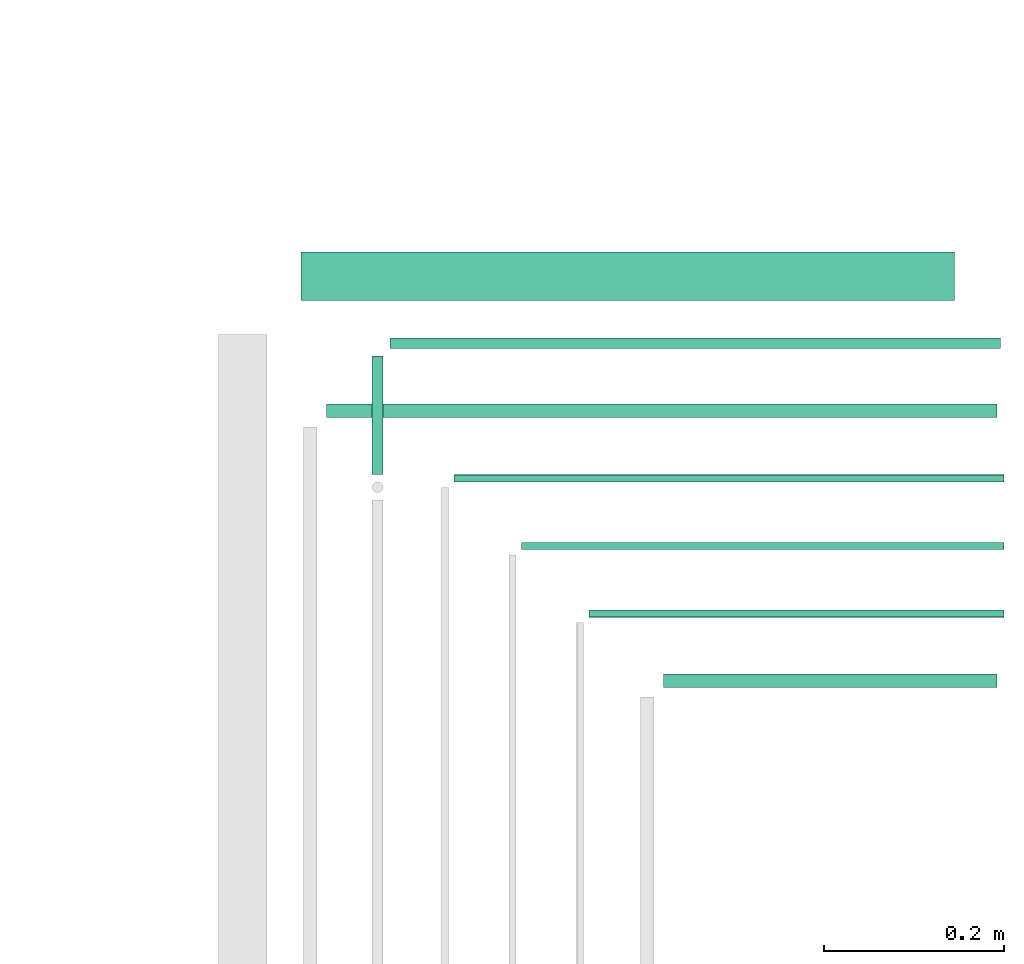
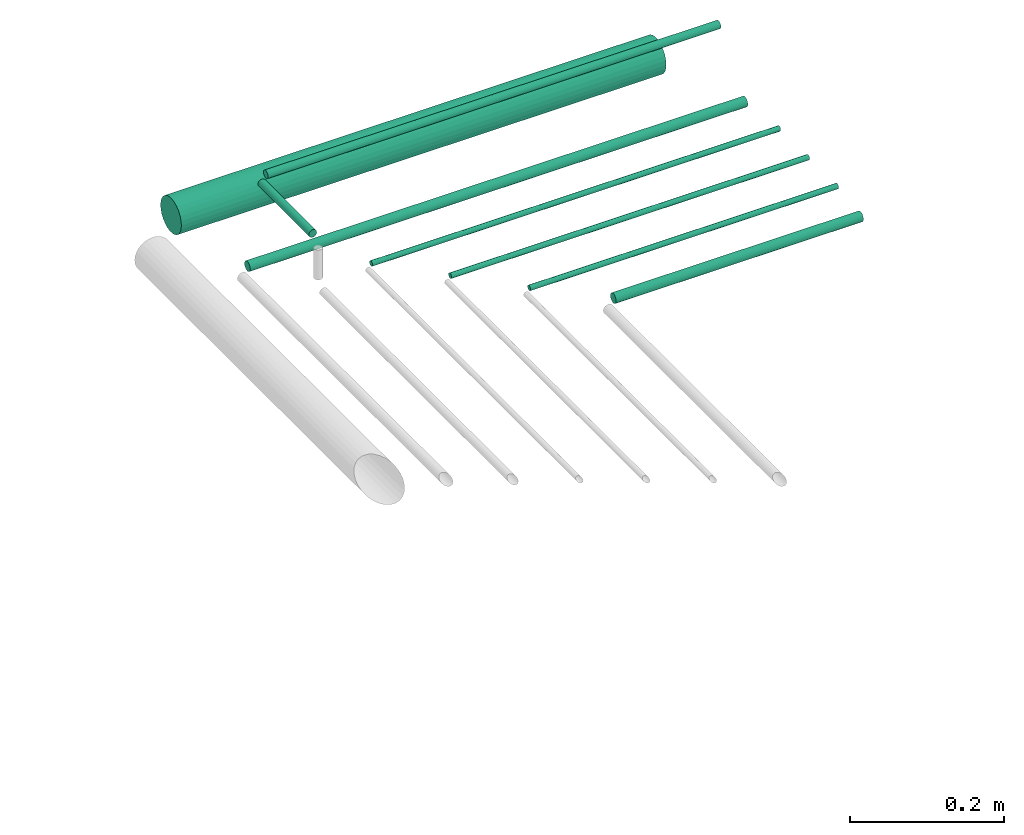
# One storey, part 47 of 65: 8 flow segments.
"""IFC2X3 building model written with IfcOpenShell, lengths in millimetres."""

import ifcopenshell
import ifcopenshell.guid

model = None  # the IFC model being written
_history = None  # IfcOwnerHistory: only IFC2X3 demands one
_inside = {}  # id of a spatial element -> (the spatial element, [elements in it])
_under = {}  # id of a project, library or spatial element -> (it, [spatial elements below it])
_declared = {}  # id of a project -> (the project, [libraries it declares])
_typed = {}  # id of a type object -> (the type object, [elements of that type])
_made_of = {}  # id of a material, layer set ... -> (it, [elements and type objects made of it])


def new_model(schema):
    """Start an empty IFC model of exactly this schema.

    Asked for "IFC4X3", IfcOpenShell would pick the latest addendum, in which some entities
    have other attributes; the version numbers below select the first issue.
    IFC2X3 requires an IfcOwnerHistory on every rooted entity: one is made here for all.
    """
    global model, _history
    if schema == "IFC4X3":
        model = ifcopenshell.file(schema_version=(4, 3, 0, 0))
    else:
        model = ifcopenshell.file(schema=schema)
    _inside.clear()
    _under.clear()
    _declared.clear()
    _typed.clear()
    _made_of.clear()
    _history = None
    if model.schema == "IFC2X3":
        org = make("IfcOrganization", Name="unknown")
        user = make(
            "IfcPersonAndOrganization",
            ThePerson=make("IfcPerson", FamilyName="unknown"),
            TheOrganization=org,
        )
        app = make(
            "IfcApplication",
            ApplicationDeveloper=org,
            Version="unknown",
            ApplicationFullName="unknown",
            ApplicationIdentifier="unknown",
        )
        _history = make(
            "IfcOwnerHistory",
            OwningUser=user,
            OwningApplication=app,
            ChangeAction="ADDED",
            CreationDate=0,
        )
    return model


def make(cls, **values):
    """One entity of the class cls with the attributes given. An attribute that is None is left unset."""
    return model.create_entity(
        cls, **{name: value for name, value in values.items() if value is not None}
    )


def entity(cls, *values):
    """Any entity or typed value of the class cls, its attributes in the order of the schema. None: left unset."""
    e = model.create_entity(cls)
    for i, value in enumerate(values):
        if value is not None:
            e[i] = value
    return e


def rooted(cls, **values):
    """An entity with a GlobalId (a new one), such as an element, a storey or a relation."""
    return make(cls, GlobalId=ifcopenshell.guid.new(), OwnerHistory=_history, **values)


def si_unit(unit_type, name, prefix=None):
    """IfcSIUnit, for example si_unit("LENGTHUNIT", "METRE", prefix="MILLI")."""
    return make("IfcSIUnit", UnitType=unit_type, Prefix=prefix, Name=name)


def converted_unit(unit_type, name, factor, base, dimensions=None, offset=None):
    """IfcConversionBasedUnit, such as the inch: factor (a typed value) times the base unit."""
    return make(
        "IfcConversionBasedUnit"
        if offset is None
        else "IfcConversionBasedUnitWithOffset",
        ConversionOffset=offset,
        Dimensions=None
        if dimensions is None
        else entity("IfcDimensionalExponents", *dimensions),
        UnitType=unit_type,
        Name=name,
        ConversionFactor=make(
            "IfcMeasureWithUnit", ValueComponent=factor, UnitComponent=base
        ),
    )


def derived_unit(unit_type, elements):
    """IfcDerivedUnit: a product of units, each with its exponent."""
    return make(
        "IfcDerivedUnit",
        Elements=[
            make("IfcDerivedUnitElement", Unit=unit, Exponent=power)
            for unit, power in elements
        ],
        UnitType=unit_type,
    )


def assignment(units):
    """IfcUnitAssignment: the units of a project."""
    return None if units is None else make("IfcUnitAssignment", Units=units)


def point(xyz):
    """IfcCartesianPoint."""
    return None if xyz is None else make("IfcCartesianPoint", Coordinates=xyz)


def direction(xyz):
    """IfcDirection."""
    return None if xyz is None else make("IfcDirection", DirectionRatios=xyz)


def frame(location, z_axis=None, x_axis=None):
    """IfcAxis2Placement3D, a coordinate frame: its origin and axes. An axis left out is left unset."""
    return make(
        "IfcAxis2Placement3D",
        Location=point(location),
        Axis=direction(z_axis),
        RefDirection=direction(x_axis),
    )


def frame_2d(location, x_axis=None):
    """IfcAxis2Placement2D, a coordinate frame in the plane: its origin and x axis."""
    return make(
        "IfcAxis2Placement2D", Location=point(location), RefDirection=direction(x_axis)
    )


def origin():
    """The frame at (0, 0, 0) with its axes left unset."""
    return frame((0.0, 0.0, 0.0))


def origin_2d_with_axis():
    """The frame at (0, 0) in the plane with the x axis (1, 0) written out."""
    return frame_2d((0.0, 0.0), x_axis=(1.0, 0.0))


def place(relative_to, where):
    """IfcLocalPlacement: puts the frame where relative to a parent placement (None: the world)."""
    return make(
        "IfcLocalPlacement", PlacementRelTo=relative_to, RelativePlacement=where
    )


def context(
    kind, dimensions, precision=None, world=None, true_north=None, identifier=None
):
    """IfcGeometricRepresentationContext, for example the 3D "Model" context."""
    return make(
        "IfcGeometricRepresentationContext",
        ContextIdentifier=identifier,
        ContextType=kind,
        CoordinateSpaceDimension=dimensions,
        Precision=precision,
        WorldCoordinateSystem=world,
        TrueNorth=true_north,
    )


def subcontext(parent, identifier, kind, view, scale=None):
    """IfcGeometricRepresentationSubContext, for example "Body" below "Model"."""
    return make(
        "IfcGeometricRepresentationSubContext",
        ContextIdentifier=identifier,
        ContextType=kind,
        ParentContext=parent,
        TargetScale=scale,
        TargetView=view,
    )


def project(units=None, contexts=None):
    """IfcProject with its units and contexts."""
    return rooted(
        "IfcProject",
        Name="project",
        RepresentationContexts=contexts,
        UnitsInContext=assignment(units),
    )


def spatial(cls, under=None, at=None, **own):
    """A site, building, storey or space (cls), placed at a placement, below another one or the project."""
    s = rooted(cls, ObjectPlacement=at, **own)
    if under is not None:
        _under.setdefault(under.id(), (under, []))[1].append(s)
    return s


def profile(cls, at=None, kind="AREA", **sizes):
    """A parametric profile (cls). Its sizes go by their IFC names, for example OverallWidth=200.0."""
    return make(cls, ProfileType=kind, Position=at, **sizes)


def circle(**sizes):
    """IfcCircleProfileDef."""
    return profile("IfcCircleProfileDef", **sizes)


def extrude(swept, where, along, depth):
    """IfcExtrudedAreaSolid: the profile swept, set in the frame where, extruded along a direction by depth."""
    return make(
        "IfcExtrudedAreaSolid",
        SweptArea=swept,
        Position=where,
        ExtrudedDirection=direction(along),
        Depth=depth,
    )


def shape(context_of_items, identifier, shape_type, items):
    """IfcShapeRepresentation: the items that make up one representation, for example the "Body"."""
    return make(
        "IfcShapeRepresentation",
        ContextOfItems=context_of_items,
        RepresentationIdentifier=identifier,
        RepresentationType=shape_type,
        Items=items,
    )


def made_of(thing, what):
    """Note that an element or type object is made of a material, layer set ...; save() writes the relation."""
    if what is not None:
        _made_of.setdefault(what.id(), (what, []))[1].append(thing)
    return thing


def type_object(cls, material=None, **own):
    """A type object (cls), such as IfcWallType, which elements share."""
    return made_of(rooted(cls, **own), material)


def element(
    cls,
    number,
    at=None,
    inside=None,
    cuts=None,
    type_object=None,
    material=None,
    context=None,
    identifier="Body",
    shape_type=None,
    held_by="IfcProductDefinitionShape",
    body=None,
    shapes=None,
    **own,
):
    """One element of the class cls, such as IfcWall. Its Tag is "e" and its number.

    at: its placement. inside: the storey or other place that contains it. cuts: it is an
    opening in that element (IfcRelVoidsElement). A single representation is given by context,
    identifier, shape_type and body (its items); several are given by shapes. held_by: the class
    of the entity that holds the representations. save() writes the other relations.
    """
    e = rooted(cls, Tag="e%d" % number, ObjectPlacement=at, **own)
    if body is not None:
        shapes = [shape(context, identifier, shape_type, body)]
    if shapes is not None:
        e.Representation = make(held_by, Representations=shapes)
    if inside is not None:
        _inside.setdefault(inside.id(), (inside, []))[1].append(e)
    if cuts is not None:
        rooted(
            "IfcRelVoidsElement", RelatingBuildingElement=cuts, RelatedOpeningElement=e
        )
    if type_object is not None:
        _typed.setdefault(type_object.id(), (type_object, []))[1].append(e)
    return made_of(e, material)


def aggregate(whole, parts):
    """IfcRelAggregates: a whole, such as a stair, and the parts it consists of."""
    return rooted("IfcRelAggregates", RelatingObject=whole, RelatedObjects=parts)


def save(model, path):
    """Write the relations noted so far, then the file.

    IfcRelAggregates (storeys below a building ...), IfcRelContainedInSpatialStructure (elements
    in a storey), IfcRelDefinesByType, IfcRelAssociatesMaterial and IfcRelDeclares: one each for
    every whole, place, type object, material and project.
    """
    for whole, parts in _under.values():
        aggregate(whole, parts)
    for where, things in _inside.values():
        rooted(
            "IfcRelContainedInSpatialStructure",
            RelatedElements=things,
            RelatingStructure=where,
        )
    for kind, things in _typed.values():
        rooted("IfcRelDefinesByType", RelatedObjects=things, RelatingType=kind)
    for what, things in _made_of.values():
        rooted("IfcRelAssociatesMaterial", RelatedObjects=things, RelatingMaterial=what)
    for by, libraries in _declared.values():
        rooted("IfcRelDeclares", RelatingContext=by, RelatedDefinitions=libraries)
    model.write(path)


model = new_model("IFC2X3")

# Units and contexts
model_context = context("Model", 3, precision=0.01, world=origin(), true_north=direction((6.12303176911189e-17, 1.0)))
body_context = subcontext(model_context, "Body", "Model", "MODEL_VIEW")
ifc_project = project(units=[si_unit("LENGTHUNIT", "METRE", prefix="MILLI"), si_unit("AREAUNIT", "SQUARE_METRE"), si_unit("VOLUMEUNIT", "CUBIC_METRE"), converted_unit("PLANEANGLEUNIT", "DEGREE", entity("IfcRatioMeasure", 0.0174532925199433), si_unit("PLANEANGLEUNIT", "RADIAN"), dimensions=[0, 0, 0, 0, 0, 0, 0]), si_unit("MASSUNIT", "GRAM", prefix="KILO"), derived_unit("MASSDENSITYUNIT", [(si_unit("MASSUNIT", "GRAM", prefix="KILO"), 1), (si_unit("LENGTHUNIT", "METRE"), -3)]), derived_unit("MOMENTOFINERTIAUNIT", [(si_unit("LENGTHUNIT", "METRE"), 4)]), si_unit("TIMEUNIT", "SECOND"), si_unit("FREQUENCYUNIT", "HERTZ"), si_unit("THERMODYNAMICTEMPERATUREUNIT", "DEGREE_CELSIUS"), derived_unit("THERMALTRANSMITTANCEUNIT", [(si_unit("MASSUNIT", "GRAM", prefix="KILO"), 1), (si_unit("THERMODYNAMICTEMPERATUREUNIT", "KELVIN"), -1), (si_unit("TIMEUNIT", "SECOND"), -3)]), derived_unit("VOLUMETRICFLOWRATEUNIT", [(si_unit("LENGTHUNIT", "METRE"), 3), (si_unit("TIMEUNIT", "SECOND"), -1)]), derived_unit("MASSFLOWRATEUNIT", [(si_unit("MASSUNIT", "GRAM", prefix="KILO"), 1), (si_unit("TIMEUNIT", "SECOND"), -1)]), derived_unit("ROTATIONALFREQUENCYUNIT", [(si_unit("TIMEUNIT", "SECOND"), -1)]), si_unit("ELECTRICCURRENTUNIT", "AMPERE"), si_unit("ELECTRICVOLTAGEUNIT", "VOLT"), si_unit("POWERUNIT", "WATT"), si_unit("FORCEUNIT", "NEWTON", prefix="KILO"), si_unit("ILLUMINANCEUNIT", "LUX"), si_unit("LUMINOUSFLUXUNIT", "LUMEN"), si_unit("LUMINOUSINTENSITYUNIT", "CANDELA"), derived_unit("USERDEFINED", [(si_unit("MASSUNIT", "GRAM", prefix="KILO"), -1), (si_unit("LENGTHUNIT", "METRE"), -2), (si_unit("TIMEUNIT", "SECOND"), 3), (si_unit("LUMINOUSFLUXUNIT", "LUMEN"), 1)]), derived_unit("LINEARVELOCITYUNIT", [(si_unit("LENGTHUNIT", "METRE"), 1), (si_unit("TIMEUNIT", "SECOND"), -1)]), si_unit("PRESSUREUNIT", "PASCAL"), derived_unit("USERDEFINED", [(si_unit("LENGTHUNIT", "METRE"), -2), (si_unit("MASSUNIT", "GRAM", prefix="KILO"), 1), (si_unit("TIMEUNIT", "SECOND"), -2)]), derived_unit("LINEARFORCEUNIT", [(si_unit("MASSUNIT", "GRAM", prefix="KILO"), 1), (si_unit("LENGTHUNIT", "METRE"), 1), (si_unit("TIMEUNIT", "SECOND"), -2), (si_unit("LENGTHUNIT", "METRE"), -1)]), derived_unit("PLANARFORCEUNIT", [(si_unit("MASSUNIT", "GRAM", prefix="KILO"), 1), (si_unit("LENGTHUNIT", "METRE"), 1), (si_unit("TIMEUNIT", "SECOND"), -2), (si_unit("LENGTHUNIT", "METRE"), -2)])], contexts=[model_context])

# Site, building, storey
site_placement = place(None, frame((0.0, -0.00077364408347762, 0.0)))
site = spatial("IfcSite", under=ifc_project, at=site_placement, CompositionType="ELEMENT")
building_placement = place(site_placement, origin())
building = spatial("IfcBuilding", under=site, at=building_placement, CompositionType="ELEMENT")
storey_placement = place(building_placement, frame((0.0, 0.0, 19800.0)))
storey = spatial("IfcBuildingStorey", under=building, at=storey_placement, CompositionType="ELEMENT", Elevation=19800.0)

# Flow segments
pipe_segment_type = type_object("IfcPipeSegmentType", PredefinedType="NOTDEFINED")
flow_segment_1_placement = place(storey_placement, frame((72918.1766297108, 10350.7754696782, 3040.90472776408)))
element("IfcFlowSegment", 1, at=flow_segment_1_placement, inside=storey, type_object=pipe_segment_type, context=body_context, shape_type="SweptSolid", body=[
    extrude(circle(Radius=7.5, at=frame_2d((-2.16573425859679e-12, 0.0), x_axis=(1.0, 0.0))), frame((0.0, 9.09527223591636, 9.09527223591419), z_axis=(1.0, 0.0, 0.0), x_axis=(0.0, 1.0, 0.0)), (0.0, 0.0, 1.0), 370.520903233842),
])
flow_segment_2_placement = place(storey_placement, frame((72835.1766297108, 10428.8573992404, 3044.40472776407)))
element("IfcFlowSegment", 2, at=flow_segment_2_placement, inside=storey, type_object=pipe_segment_type, context=body_context, shape_type="SweptSolid", body=[
    extrude(circle(Radius=4.0, at=frame_2d((-4.33146851719357e-12, 0.0), x_axis=(1.0, 0.0))), frame((0.0, 5.59527223591932, 5.59527223591499), z_axis=(1.0, 0.0, 0.0), x_axis=(0.0, 1.0, 0.0)), (0.0, 0.0, 1.0), 461.520903233838),
])
flow_segment_3_placement = place(storey_placement, frame((72760.1766297108, 10504.10062571, 3044.40472776407)))
element("IfcFlowSegment", 3, at=flow_segment_3_placement, inside=storey, type_object=pipe_segment_type, context=body_context, shape_type="SweptSolid", body=[
    extrude(circle(Radius=4.0, at=frame_2d((-6.49720277579036e-12, 0.0), x_axis=(1.0, 0.0))), frame((0.0, 5.59527223592149, 5.59527223591499), z_axis=(1.0, 0.0, 0.0), x_axis=(0.0, 1.0, 0.0)), (0.0, 0.0, 1.0), 536.520903233847),
])
flow_segment_4_placement = place(storey_placement, frame((72685.1766297108, 10579.3450681631, 3044.40472776407)))
element("IfcFlowSegment", 4, at=flow_segment_4_placement, inside=storey, type_object=pipe_segment_type, context=body_context, shape_type="SweptSolid", body=[
    extrude(circle(Radius=4.0, at=frame_2d((-6.49720277579036e-12, 0.0), x_axis=(1.0, 0.0))), frame((0.0, 5.59527223592149, 5.59527223591499), z_axis=(1.0, 0.0, 0.0), x_axis=(0.0, 1.0, 0.0)), (0.0, 0.0, 1.0), 611.520903233873),
])
flow_segment_5_placement = place(storey_placement, frame((72543.1766297107, 10650.7784588154, 3040.90472776408)))
element("IfcFlowSegment", 5, at=flow_segment_5_placement, inside=storey, type_object=pipe_segment_type, context=body_context, shape_type="SweptSolid", body=[
    extrude(circle(Radius=7.5, at=origin_2d_with_axis()), frame((0.0, 9.09527223591636, 9.09527223591419), z_axis=(1.0, 0.0, 0.0), x_axis=(0.0, 1.0, 0.0)), (0.0, 0.0, 1.0), 745.520903233904),
])
flow_segment_6_placement = place(storey_placement, frame((72614.1766297107, 10727.5815154138, 3117.40472776409)))
element("IfcFlowSegment", 6, at=flow_segment_6_placement, inside=storey, type_object=pipe_segment_type, context=body_context, shape_type="SweptSolid", body=[
    extrude(circle(Radius=6.0, at=frame_2d((-6.49720277579036e-12, 0.0), x_axis=(1.0, 0.0))), frame((0.0, 7.5952722359232, 7.59527223591454), z_axis=(1.0, 0.0, 0.0), x_axis=(0.0, 1.0, 0.0)), (0.0, 0.0, 1.0), 678.520903233919),
])
flow_segment_7_placement = place(storey_placement, frame((72515.1766297108, 10781.1546458955, 3021.40472776408)))
element("IfcFlowSegment", 7, at=flow_segment_7_placement, inside=storey, type_object=pipe_segment_type, context=body_context, shape_type="SweptSolid", body=[
    extrude(circle(Radius=27.0, at=frame_2d((-4.33146851719357e-12, 0.0), x_axis=(1.0, 0.0))), frame((0.0, 28.5952722359206, 28.5952722359141), z_axis=(1.0, 0.0, 0.0), x_axis=(0.0, 1.0, 0.0)), (0.0, 0.0, 1.0), 726.520903233856),
])
flow_segment_8_placement = place(storey_placement, frame((72592.5813574748, 10588.940340399, 3117.40472776409)))
element("IfcFlowSegment", 8, at=flow_segment_8_placement, inside=storey, type_object=pipe_segment_type, context=body_context, shape_type="SweptSolid", body=[
    extrude(circle(Radius=6.0, at=origin_2d_with_axis()), frame((7.59527223591454, 0.0, 7.59527223591454), z_axis=(0.0, 1.0, 0.0), x_axis=(1.0, 0.0, 0.0)), (0.0, 0.0, 1.0), 132.236447250703),
])

save(model, "model.ifc")
